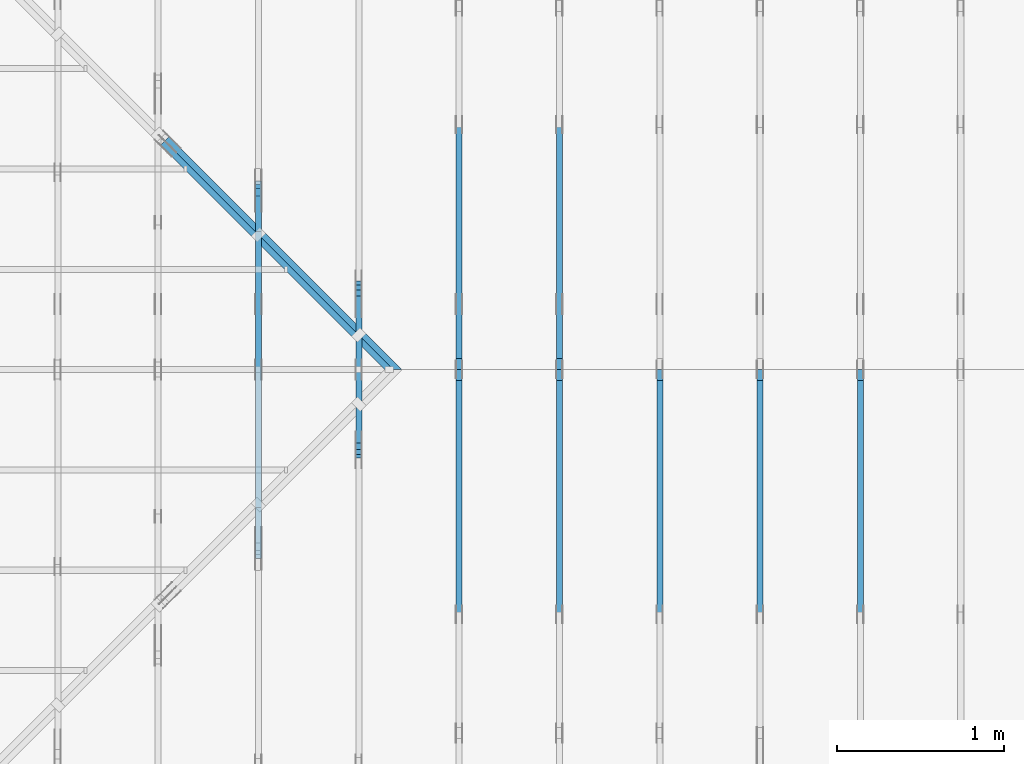
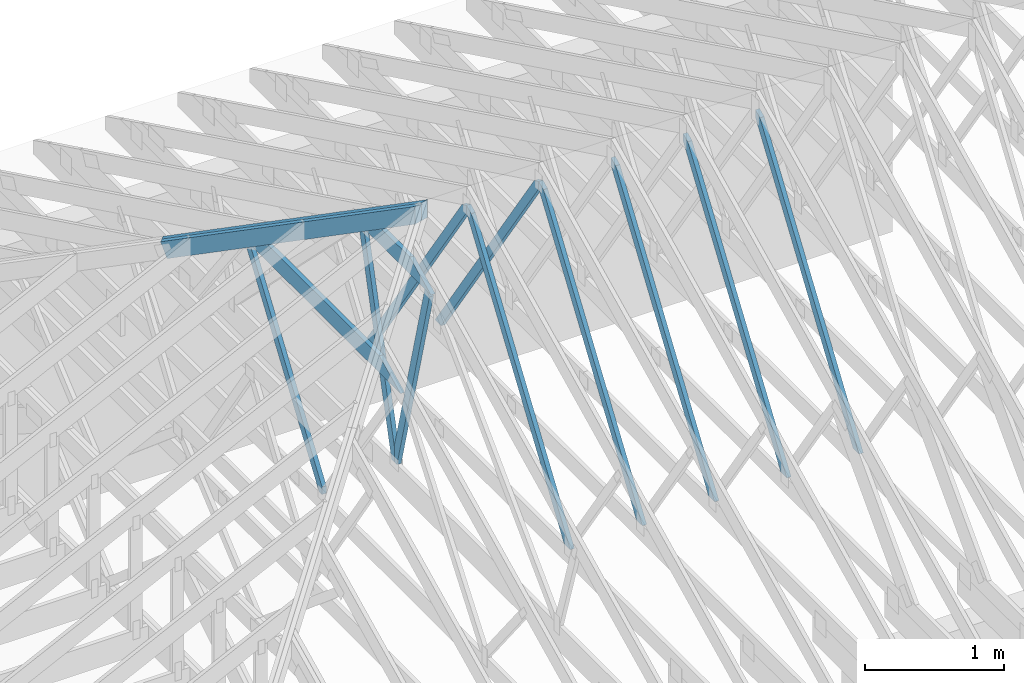
# One storey, part 9 of 159: 14 members, 8 elements without a shape of their own.
"""IFC2X3 building model written with IfcOpenShell, lengths in millimetres."""

from ifc_helpers import new_model, si_unit, frame, origin, origin_with_axes, origin_2d, place, context, project, spatial, faceted_brep, element, aggregate, save


model = new_model("IFC2X3")

# Units and contexts
model_context = context("Model", 3, precision=1e-05, world=origin())
plan_context = context("Plan", 2, precision=1e-05, world=origin_2d())
ifc_project = project(units=[si_unit("LENGTHUNIT", "METRE", prefix="MILLI"), si_unit("AREAUNIT", "SQUARE_METRE"), si_unit("VOLUMEUNIT", "CUBIC_METRE"), si_unit("SOLIDANGLEUNIT", "STERADIAN"), si_unit("PLANEANGLEUNIT", "RADIAN"), si_unit("MASSUNIT", "GRAM"), si_unit("TIMEUNIT", "SECOND"), si_unit("THERMODYNAMICTEMPERATUREUNIT", "DEGREE_CELSIUS"), si_unit("LUMINOUSINTENSITYUNIT", "LUMEN")], contexts=[model_context, plan_context])

# Site, building, storey
site_placement = place(None, origin_with_axes())
site = spatial("IfcSite", under=ifc_project, at=site_placement, CompositionType="ELEMENT")
building_placement = place(site_placement, origin_with_axes())
building = spatial("IfcBuilding", under=site, at=building_placement, Name="Plan 1", CompositionType="ELEMENT")
storey_placement = place(building_placement, origin_with_axes())
storey = spatial("IfcBuildingStorey", under=building, at=storey_placement, Name="Etasje 1", CompositionType="ELEMENT", Elevation=0.0)

# Assembly, member
assembly_1_placement = place(storey_placement, frame((7275.0222614047525, 9699.99999999999, 1.1021457184401395e-15), z_axis=(-1.0, 1.836909530733566e-16, 6.123031769111886e-17), x_axis=(-1.836909530733566e-16, -1.0, 0.0)))
assembly_1 = element("IfcElementAssembly", 1, at=assembly_1_placement, inside=storey, Name="T2 (90)", AssemblyPlace="FACTORY", PredefinedType="TRUSS")
member_1_placement = place(assembly_1_placement, frame((5169.864836410244, 2470.9491092698727, -36.0), z_axis=(0.0, 0.0, 1.0), x_axis=(0.5642475050070653, -0.8256056886270235, 0.0)))
member_1 = element("IfcMember", 2, at=member_1_placement, Name="T2-D10", context=model_context, shape_type="Brep", body=[
    faceted_brep([(2593.4163311647535, 73.00017519343237, 36.0), (64.12142578858538, 73.00017519343237, 36.0), (0.0, 36.50008196845101, 36.0), (53.406771110838235, 4.597682982421247e-05, 36.0), (2543.525610853865, 4.597682982421247e-05, 36.0), (64.12142578858538, 73.00017519343237, 7.85235054368517e-15), (2593.4163311647535, 73.00017519343237, 3.175914117251076e-13), (2543.525610853865, 4.597682982421247e-05, 3.1148176241615866e-13), (53.406771110838235, 4.597682982421247e-05, 6.540227123946988e-15), (0.0, 36.50008196845101, 0.0), (3.725174792457153e-05, 36.50000000048476, 5.564110112461459e-32), (3.725174792634789e-05, 36.50000000048476, 36.0), (64.12144158370505, 73.0000000000009, 36.0), (64.12144158370505, 73.0000000000009, -5.058610251535388e-31), (53.40675570041139, -3.552713678800501e-15, 3.944304526105059e-31), (53.40675570041139, 0.0, 36.0), (3.725174792634789e-05, 36.50000000048476, 36.0), (3.725174792634789e-05, 36.50000000048476, 0.0), (2543.5254846197568, 1.0633235970486703e-11, -9.418992127807544e-29), (2543.5254846197568, 1.0635440261923583e-11, 36.0), (53.406755700411395, 3.450395691825015e-14, 36.0), (53.406755700411395, 3.229966548136987e-14, -1.9777187787411422e-30), (2593.4162114315045, 73.00000000000773, 2.524354896707238e-29), (2593.4162114315045, 73.00000000000773, 36.0), (2543.525484619757, 8.86757334228605e-12, 36.0), (2543.525484619757, 8.86757334228605e-12, 0.0), (64.12144158370506, 73.00000000000092, 0.0), (64.12144158370506, 73.00000000000092, 36.0), (2593.416211431504, 73.00000000000863, 36.0), (2593.416211431504, 73.00000000000863, 2.68212707775144e-29)], [[[0, 1, 2, 3, 4]], [[5, 6, 7, 8, 9]], [[10, 11, 12, 13]], [[14, 15, 16, 17]], [[18, 19, 20, 21]], [[22, 23, 24, 25]], [[26, 27, 28, 29]]]),
])
aggregate(assembly_1, [member_1])

assembly_2_placement = place(storey_placement, frame((6675.0222614047525, 9699.99999999999, 1.1021457184401395e-15), z_axis=(-1.0, 1.836909530733566e-16, 6.123031769111886e-17), x_axis=(-1.836909530733566e-16, -1.0, 0.0)))
assembly_2 = element("IfcElementAssembly", 3, at=assembly_2_placement, inside=storey, Name="T2 (89)", AssemblyPlace="FACTORY", PredefinedType="TRUSS")
member_2_placement = place(assembly_2_placement, frame((5169.864836410244, 2470.9491092698727, -36.0), z_axis=(0.0, 0.0, 1.0), x_axis=(0.5642475050070653, -0.8256056886270235, 0.0)))
member_2 = element("IfcMember", 4, at=member_2_placement, Name="T2-D10", context=model_context, shape_type="Brep", body=[
    faceted_brep([(2593.4163311647535, 73.00017519343237, 36.0), (64.12142578858538, 73.00017519343237, 36.0), (0.0, 36.50008196845101, 36.0), (53.406771110838235, 4.597682982421247e-05, 36.0), (2543.525610853865, 4.597682982421247e-05, 36.0), (64.12142578858538, 73.00017519343237, 7.85235054368517e-15), (2593.4163311647535, 73.00017519343237, 3.175914117251076e-13), (2543.525610853865, 4.597682982421247e-05, 3.1148176241615866e-13), (53.406771110838235, 4.597682982421247e-05, 6.540227123946988e-15), (0.0, 36.50008196845101, 0.0), (3.725174792457153e-05, 36.50000000048476, 5.564110112461459e-32), (3.725174792634789e-05, 36.50000000048476, 36.0), (64.12144158370505, 73.0000000000009, 36.0), (64.12144158370505, 73.0000000000009, -5.058610251535388e-31), (53.40675570041139, -3.552713678800501e-15, 3.944304526105059e-31), (53.40675570041139, 0.0, 36.0), (3.725174792634789e-05, 36.50000000048476, 36.0), (3.725174792634789e-05, 36.50000000048476, 0.0), (2543.5254846197568, 1.0633235970486703e-11, -9.418992127807544e-29), (2543.5254846197568, 1.0635440261923583e-11, 36.0), (53.406755700411395, 3.450395691825015e-14, 36.0), (53.406755700411395, 3.229966548136987e-14, -1.9777187787411422e-30), (2593.4162114315045, 73.00000000000773, 2.524354896707238e-29), (2593.4162114315045, 73.00000000000773, 36.0), (2543.525484619757, 8.86757334228605e-12, 36.0), (2543.525484619757, 8.86757334228605e-12, 0.0), (64.12144158370506, 73.00000000000092, 0.0), (64.12144158370506, 73.00000000000092, 36.0), (2593.416211431504, 73.00000000000863, 36.0), (2593.416211431504, 73.00000000000863, 2.68212707775144e-29)], [[[0, 1, 2, 3, 4]], [[5, 6, 7, 8, 9]], [[10, 11, 12, 13]], [[14, 15, 16, 17]], [[18, 19, 20, 21]], [[22, 23, 24, 25]], [[26, 27, 28, 29]]]),
])
aggregate(assembly_2, [member_2])

# Assembly, members
assembly_3_placement = place(storey_placement, frame((5475.0222614047525, 9699.99999999999, 1.1021457184401395e-15), z_axis=(-1.0, 1.836909530733566e-16, 6.123031769111886e-17), x_axis=(-1.836909530733566e-16, -1.0, 0.0)))
assembly_3 = element("IfcElementAssembly", 5, at=assembly_3_placement, inside=storey, Name="T1 (87)", AssemblyPlace="FACTORY", PredefinedType="TRUSS")
member_3_placement = place(assembly_3_placement, frame((5169.864827117615, 2512.139275987297, -36.0), z_axis=(0.0, 0.0, 1.0), x_axis=(-0.564247505007381, -0.8256056886268078, 0.0)))
member_3 = element("IfcMember", 6, at=member_3_placement, Name="T1-D10", context=model_context, shape_type="Brep", body=[
    faceted_brep([(2543.525473098112, 73.00019205182707, 36.0), (53.406771110823684, 73.00019205182707, 36.0), (0.0, 36.5000932239891, 36.0), (64.12142578859857, 0.00011835385657832376, 36.0), (2593.4163311647667, 0.00011835385657832376, 36.0), (53.406771110823684, 73.00019205182707, 6.540227123945206e-15), (2543.525473098112, 73.00019205182707, 3.114817455465016e-13), (2593.4163311647667, 0.00011835385657832376, 3.175914117251092e-13), (64.12142578859857, 0.00011835385657832376, 7.852350543686785e-15), (0.0, 36.5000932239891, 0.0), (8.990056994662154e-05, 36.50009815631665, 3.944304526105059e-31), (8.990056994662154e-05, 36.50009815631665, 36.0), (53.40680834923387, 73.00009815680099, 36.0), (53.40680834923387, 73.00009815680099, 7.888609052210118e-31), (64.12149423256596, 9.815680185809583e-05, 6.171430365172586e-31), (64.12149423256596, 9.815680186164855e-05, 36.0), (8.990056995195062e-05, 36.50009815631667, 36.0), (8.990056995017426e-05, 36.50009815631666, -3.3878954237129854e-31), (2593.4162640810096, 9.815680364966906e-05, 2.3313020864942917e-30), (2593.4162640810096, 9.815680365187335e-05, 36.0), (64.12149423256596, 9.815680187001689e-05, 36.0), (64.12149423256596, 9.81568018678126e-05, 5.76409767496333e-32), (2543.5255372692222, 73.00009815680278, 0.0), (2543.5255372692222, 73.00009815680278, 36.0), (2593.4162640810096, 9.815680414249073e-05, 36.0), (2593.4162640810096, 9.815680414249073e-05, 0.0), (53.40680834923387, 73.00009815680097, 7.888609052210118e-31), (53.40680834923387, 73.00009815680097, 36.0), (2543.525537269222, 73.00009815680359, 36.0), (2543.525537269222, 73.00009815680359, 4.9698237028923744e-29)], [[[0, 1, 2, 3, 4]], [[5, 6, 7, 8, 9]], [[10, 11, 12, 13]], [[14, 15, 16, 17]], [[18, 19, 20, 21]], [[22, 23, 24, 25]], [[26, 27, 28, 29]]]),
])
member_4_placement = place(assembly_3_placement, frame((5169.864836410244, 2470.9491092698727, -36.0), z_axis=(0.0, 0.0, 1.0), x_axis=(0.5642475050070653, -0.8256056886270235, 0.0)))
member_4 = element("IfcMember", 7, at=member_4_placement, Name="T1-D10", context=model_context, shape_type="Brep", body=[
    faceted_brep([(2593.4163311647535, 73.00017519343237, 36.0), (64.12142578858538, 73.00017519343237, 36.0), (0.0, 36.50008196845101, 36.0), (53.406771110838235, 4.597682982421247e-05, 36.0), (2543.525610853865, 4.597682982421247e-05, 36.0), (64.12142578858538, 73.00017519343237, 7.85235054368517e-15), (2593.4163311647535, 73.00017519343237, 3.175914117251076e-13), (2543.525610853865, 4.597682982421247e-05, 3.1148176241615866e-13), (53.406771110838235, 4.597682982421247e-05, 6.540227123946988e-15), (0.0, 36.50008196845101, 0.0), (3.725174792457153e-05, 36.50000000048476, 5.564110112461459e-32), (3.725174792634789e-05, 36.50000000048476, 36.0), (64.12144158370505, 73.0000000000009, 36.0), (64.12144158370505, 73.0000000000009, -5.058610251535388e-31), (53.40675570041139, -3.552713678800501e-15, 3.944304526105059e-31), (53.40675570041139, 0.0, 36.0), (3.725174792634789e-05, 36.50000000048476, 36.0), (3.725174792634789e-05, 36.50000000048476, 0.0), (2543.5254846197568, 1.0633235970486703e-11, -9.418992127807544e-29), (2543.5254846197568, 1.0635440261923583e-11, 36.0), (53.406755700411395, 3.450395691825015e-14, 36.0), (53.406755700411395, 3.229966548136987e-14, -1.9777187787411422e-30), (2593.4162114315045, 73.00000000000773, 2.524354896707238e-29), (2593.4162114315045, 73.00000000000773, 36.0), (2543.525484619757, 8.86757334228605e-12, 36.0), (2543.525484619757, 8.86757334228605e-12, 0.0), (64.12144158370506, 73.00000000000092, 0.0), (64.12144158370506, 73.00000000000092, 36.0), (2593.416211431504, 73.00000000000863, 36.0), (2593.416211431504, 73.00000000000863, 2.68212707775144e-29)], [[[0, 1, 2, 3, 4]], [[5, 6, 7, 8, 9]], [[10, 11, 12, 13]], [[14, 15, 16, 17]], [[18, 19, 20, 21]], [[22, 23, 24, 25]], [[26, 27, 28, 29]]]),
])
aggregate(assembly_3, [member_3, member_4])

assembly_4_placement = place(storey_placement, frame((4875.0222614047525, 9699.99999999999, 1.1021457184401395e-15), z_axis=(-1.0, 1.836909530733566e-16, 6.123031769111886e-17), x_axis=(-1.836909530733566e-16, -1.0, 0.0)))
assembly_4 = element("IfcElementAssembly", 8, at=assembly_4_placement, inside=storey, Name="T1 (86)", AssemblyPlace="FACTORY", PredefinedType="TRUSS")
member_5_placement = place(assembly_4_placement, frame((5169.864827117615, 2512.139275987297, -36.0), z_axis=(0.0, 0.0, 1.0), x_axis=(-0.564247505007381, -0.8256056886268078, 0.0)))
member_5 = element("IfcMember", 9, at=member_5_placement, Name="T1-D10", context=model_context, shape_type="Brep", body=[
    faceted_brep([(2543.525473098112, 73.00019205182707, 36.0), (53.406771110823684, 73.00019205182707, 36.0), (0.0, 36.5000932239891, 36.0), (64.12142578859857, 0.00011835385657832376, 36.0), (2593.4163311647667, 0.00011835385657832376, 36.0), (53.406771110823684, 73.00019205182707, 6.540227123945206e-15), (2543.525473098112, 73.00019205182707, 3.114817455465016e-13), (2593.4163311647667, 0.00011835385657832376, 3.175914117251092e-13), (64.12142578859857, 0.00011835385657832376, 7.852350543686785e-15), (0.0, 36.5000932239891, 0.0), (8.990056994662154e-05, 36.50009815631665, 3.944304526105059e-31), (8.990056994662154e-05, 36.50009815631665, 36.0), (53.40680834923387, 73.00009815680099, 36.0), (53.40680834923387, 73.00009815680099, 7.888609052210118e-31), (64.12149423256596, 9.815680185809583e-05, 6.171430365172586e-31), (64.12149423256596, 9.815680186164855e-05, 36.0), (8.990056995195062e-05, 36.50009815631667, 36.0), (8.990056995017426e-05, 36.50009815631666, -3.3878954237129854e-31), (2593.4162640810096, 9.815680364966906e-05, 2.3313020864942917e-30), (2593.4162640810096, 9.815680365187335e-05, 36.0), (64.12149423256596, 9.815680187001689e-05, 36.0), (64.12149423256596, 9.81568018678126e-05, 5.76409767496333e-32), (2543.5255372692222, 73.00009815680278, 0.0), (2543.5255372692222, 73.00009815680278, 36.0), (2593.4162640810096, 9.815680414249073e-05, 36.0), (2593.4162640810096, 9.815680414249073e-05, 0.0), (53.40680834923387, 73.00009815680097, 7.888609052210118e-31), (53.40680834923387, 73.00009815680097, 36.0), (2543.525537269222, 73.00009815680359, 36.0), (2543.525537269222, 73.00009815680359, 4.9698237028923744e-29)], [[[0, 1, 2, 3, 4]], [[5, 6, 7, 8, 9]], [[10, 11, 12, 13]], [[14, 15, 16, 17]], [[18, 19, 20, 21]], [[22, 23, 24, 25]], [[26, 27, 28, 29]]]),
])
member_6_placement = place(assembly_4_placement, frame((5169.864836410244, 2470.9491092698727, -36.0), z_axis=(0.0, 0.0, 1.0), x_axis=(0.5642475050070653, -0.8256056886270235, 0.0)))
member_6 = element("IfcMember", 10, at=member_6_placement, Name="T1-D10", context=model_context, shape_type="Brep", body=[
    faceted_brep([(2593.4163311647535, 73.00017519343237, 36.0), (64.12142578858538, 73.00017519343237, 36.0), (0.0, 36.50008196845101, 36.0), (53.406771110838235, 4.597682982421247e-05, 36.0), (2543.525610853865, 4.597682982421247e-05, 36.0), (64.12142578858538, 73.00017519343237, 7.85235054368517e-15), (2593.4163311647535, 73.00017519343237, 3.175914117251076e-13), (2543.525610853865, 4.597682982421247e-05, 3.1148176241615866e-13), (53.406771110838235, 4.597682982421247e-05, 6.540227123946988e-15), (0.0, 36.50008196845101, 0.0), (3.725174792457153e-05, 36.50000000048476, 5.564110112461459e-32), (3.725174792634789e-05, 36.50000000048476, 36.0), (64.12144158370505, 73.0000000000009, 36.0), (64.12144158370505, 73.0000000000009, -5.058610251535388e-31), (53.40675570041139, -3.552713678800501e-15, 3.944304526105059e-31), (53.40675570041139, 0.0, 36.0), (3.725174792634789e-05, 36.50000000048476, 36.0), (3.725174792634789e-05, 36.50000000048476, 0.0), (2543.5254846197568, 1.0633235970486703e-11, -9.418992127807544e-29), (2543.5254846197568, 1.0635440261923583e-11, 36.0), (53.406755700411395, 3.450395691825015e-14, 36.0), (53.406755700411395, 3.229966548136987e-14, -1.9777187787411422e-30), (2593.4162114315045, 73.00000000000773, 2.524354896707238e-29), (2593.4162114315045, 73.00000000000773, 36.0), (2543.525484619757, 8.86757334228605e-12, 36.0), (2543.525484619757, 8.86757334228605e-12, 0.0), (64.12144158370506, 73.00000000000092, 0.0), (64.12144158370506, 73.00000000000092, 36.0), (2593.416211431504, 73.00000000000863, 36.0), (2593.416211431504, 73.00000000000863, 2.68212707775144e-29)], [[[0, 1, 2, 3, 4]], [[5, 6, 7, 8, 9]], [[10, 11, 12, 13]], [[14, 15, 16, 17]], [[18, 19, 20, 21]], [[22, 23, 24, 25]], [[26, 27, 28, 29]]]),
])
aggregate(assembly_4, [member_5, member_6])

assembly_5_placement = place(storey_placement, frame((-725.455844122723, 9674.544155877278, 2.204291436880279e-15), z_axis=(-0.7071067811865477, -0.7071067811865474, 6.123031769111886e-17), x_axis=(0.7071067811865474, -0.7071067811865477, 0.0)))
assembly_5 = element("IfcElementAssembly", 11, at=assembly_5_placement, inside=storey, Name="GR1 (7)", AssemblyPlace="FACTORY", PredefinedType="TRUSS")
member_7_placement = place(assembly_5_placement, frame((5468.934471170818, 1837.150671481754, -36.00000195234122), z_axis=(0.0, 0.0, 1.0), x_axis=(0.9453579955214152, 0.32603413978252627, 0.0)))
member_7 = element("IfcMember", 12, at=member_7_placement, Name="GR1-O54.1", context=model_context, shape_type="Brep", body=[
    faceted_brep([(2044.9695853527853, 148.00000217906904, 3.895812142218347e-06), (2006.888773817072, 147.99999829813834, 36.000002291727014), (1955.8466796875005, 5.297806637827307e-11, 36.00000195234145), (1993.9274912232138, 2.541803496569628e-07, 2.3739650032439386e-06), (0.00010288836256222567, 148.00000000101932, 1.952341222022369e-06), (0.00010288836256222567, 148.00000000101932, 36.00000195234122), (2006.8887747633617, 148.00000000101966, 36.00000195234122), (2044.9695853102367, 148.00000000101966, 1.952341222022369e-06), (0.00010423553885630099, 148.0000000027635, 1.9523412220223817e-06), (2044.9695866574139, 148.0000000027635, 1.952341472450644e-06), (1993.9274914730877, 9.86574377748184e-10, 1.9523414661999965e-06), (0.00010423553885630099, 9.86574377748184e-10, 1.9523412220223817e-06), (5.277855416352395e-05, 3.7843392419745214e-07, 1.8783537143463036e-06), (5.277855325445718e-05, 3.7843392419745214e-07, 36.00000195234122), (5.277855327258134e-05, 148.00000315368334, 36.00000255341424), (5.277855418164817e-05, 148.00000315368334, 4.576700956714107e-28), (1993.927491581545, -3.662664415573603e-13, 1.952341222022369e-06), (1955.84668103467, -3.5706704973731863e-13, 36.00000195234122), (1.3471708371071145e-06, 2.204290919838e-15, 36.00000195234122), (1.3471708371071145e-06, -5.170422792220365e-22, 1.952341222022369e-06), (2006.8887748718253, 148.00000000005298, 36.00000195234122), (0.0, 148.00000000005298, 36.00000195234122), (0.0, 2.7632722776615992e-09, 36.00000195234122), (1955.8466796875, 2.7632722776615992e-09, 36.00000195234122)], [[[0, 1, 2, 3]], [[4, 5, 6, 7]], [[8, 9, 10, 11]], [[12, 13, 14, 15]], [[16, 17, 18, 19]], [[20, 21, 22, 23]]]),
])
member_8_placement = place(assembly_5_placement, frame((5468.934472444393, 1837.1506719209274, -72.00000195234122), z_axis=(0.0, 0.0, 1.0), x_axis=(0.9453579955214152, 0.32603413978252627, 0.0)))
member_8 = element("IfcMember", 13, at=member_8_placement, Name="GR1-O54.1", context=model_context, shape_type="Brep", body=[
    faceted_brep([(2083.0503958999657, 148.0000021788719, 3.895756890415214e-06), (2044.9695843641184, 147.99999829807945, 36.000002291530336), (1993.927490234375, 5.32054400537163e-11, 36.00000195234122), (2032.0083017702218, 2.5404278858331963e-07, 2.3741063159832265e-06), (0.00010288836801919388, 148.00000000104, 1.952341222022369e-06), (0.00010288836801919388, 148.00000000104, 36.00000195234122), (2044.969585310244, 148.0000000010394, 36.00000195234122), (2083.050395857119, 148.0000000010394, 1.952341222022369e-06), (5.143138423591154e-05, 3.784869022638304e-07, 1.8783537143463036e-06), (5.143138332684477e-05, 3.784869022638304e-07, 36.00000195234122), (5.143138334496893e-05, 148.00000315373632, 36.00000255341424), (5.143138425403576e-05, 148.00000315373632, 4.576700956714107e-28), (2032.0083021287628, -3.7326154150329567e-13, 1.952341222022369e-06), (1993.9274915818878, 9.157337962291024e-14, 36.00000195234122), (1.3475118976202793e-06, 4.578398206632287e-13, 36.00000195234122), (1.3475118976202793e-06, -7.981584533867967e-23, 1.952341222022369e-06), (2044.9695854187012, 148.00000000005366, 36.00000195234122), (0.0, 148.00000000005366, 36.00000195234122), (0.0, 2.8164777177153155e-09, 36.00000195234122), (1993.927490234375, 2.8164777177153155e-09, 36.00000195234122), (0.00010423588628327707, 148.00000000281625, 1.9523412220223817e-06), (2083.050397204637, 148.00000000281625, 1.952341477114044e-06), (2032.00830202031, 1.0068106348626316e-09, 1.952341470863397e-06), (0.00010423588719277177, 1.0068106348626316e-09, 1.9523412220223817e-06)], [[[0, 1, 2, 3]], [[4, 5, 6, 7]], [[8, 9, 10, 11]], [[12, 13, 14, 15]], [[16, 17, 18, 19]], [[20, 21, 22, 23]]]),
])
aggregate(assembly_5, [member_7, member_8])

assembly_6_placement = place(storey_placement, frame((3675.02226140475, 9699.999999999993, 1.1021457184401395e-15), z_axis=(-1.0, 1.836909530733566e-16, 6.123031769111886e-17), x_axis=(-1.836909530733566e-16, -1.0, 0.0)))
assembly_6 = element("IfcElementAssembly", 14, at=assembly_6_placement, inside=storey, Name="V4 (5)", AssemblyPlace="FACTORY", PredefinedType="TRUSS")
member_9_placement = place(assembly_6_placement, frame((4071.5772928510996, 1941.1758453978764, -36.0), z_axis=(0.0, 0.0, 1.0), x_axis=(1.0, 0.0, 0.0)))
member_9 = element("IfcMember", 15, at=member_9_placement, Name="V4-O52", context=model_context, shape_type="Brep", body=[
    faceted_brep([(1953.3992696489004, 147.9999358521236, 36.0), (303.4451680864004, 147.9999358521236, 36.0), (9.97270253719762e-05, 5.79224360990338e-05, 36.0), (2256.8445821489004, 5.79224360990338e-05, 36.0), (303.4451680864004, 147.9999358521236, 3.7160088087530516e-14), (1953.3992696489004, 147.9999358521236, 2.3921451571640344e-13), (2256.8445821489004, 5.79224360990338e-05, 2.763746214889151e-13), (9.97270253719762e-05, 5.79224360990338e-05, 1.2212634891832748e-20), (-1.0184798680605127e-14, 1.4572797160227418e-11, 1.4225809873699785e-30), (-9.218500915562698e-15, 1.457081595620764e-11, 36.0), (303.4449685538421, 148.00000000000722, 36.0), (303.4449685538421, 148.00000000000722, -3.951237873904853e-30), (2256.844344427198, 1.0599023640320796e-13, -6.489815847125323e-30), (2256.844344427198, 1.0819452784008824e-13, 36.0), (1.410953698965989e-29, 1.4554119519803732e-11, 36.0), (0.0, 1.4551915228366852e-11, 0.0), (1953.3993758734434, 148.0000000000001, 7.41151830467227e-30), (1953.3993758734434, 148.0000000000001, 36.0), (2256.844344427198, 2.2737367544323206e-13, 36.0), (2256.844344427198, 2.2737367544323206e-13, 6.371166506495292e-30), (303.444968553842, 148.00000000000725, -1.5777218104420236e-30), (303.444968553842, 148.00000000000725, 36.0), (1953.3993758734432, 147.9999999999998, 36.0), (1953.3993758734432, 147.99999999999983, -1.1044052673094165e-29)], [[[0, 1, 2, 3]], [[4, 5, 6, 7]], [[8, 9, 10, 11]], [[12, 13, 14, 15]], [[16, 17, 18, 19]], [[20, 21, 22, 23]]]),
])
member_10_placement = place(assembly_6_placement, frame((4087.425808578242, 1920.4581407281698, -36.0), z_axis=(0.0, 0.0, 1.0), x_axis=(0.5676061629790939, -0.8233002148354817, 0.0)))
member_10 = element("IfcMember", 16, at=member_10_placement, Name="V4-D17", context=model_context, shape_type="Brep", body=[
    faceted_brep([(1854.2304709005057, 73.00017562337689, 36.0), (25.164020344358732, 73.00017562337689, 36.0), (5.47351367004012e-05, 36.5003218901893, 36.0), (11.924960228313012, 0.00011002184874087106, 36.0), (1882.008668050445, 0.00011002184874087106, 36.0), (1907.1729108111135, 36.5003218901893, 36.0), (25.164020344358732, 73.00017562337689, 3.081601920141727e-15), (1854.2304709005057, 73.00017562337689, 2.2707024161158178e-13), (1907.1729108111135, 36.5003218901893, 2.335536064417208e-13), (1882.008668050445, 0.00011002184874087106, 2.304719772843364e-13), (11.924960228313012, 0.00011002184874087106, 1.460338206467126e-15), (5.47351367004012e-05, 36.5003218901893, 6.70289961806477e-21), (-1.0658141036401503e-14, 36.50014045123044, 7.768466366807374e-31), (-7.105427357601002e-15, 36.50014045123044, 36.0), (25.16411944927357, 73.00014045122226, 36.0), (25.16411944927357, 73.00014045122226, 1.4445050241938607e-30), (11.924987637655475, 0.00014045122225025963, 9.860761315262648e-32), (11.924987637655477, 0.0001404512222511478, 36.0), (7.105427357601002e-15, 36.50014045123045, 36.0), (5.329070518200751e-15, 36.50014045123045, -4.930380657631324e-31), (1882.0087648814429, 0.00014045122522491653, 4.0642603203748335e-29), (1882.0087648814429, 0.00014045122522712082, 36.0), (11.924987637655477, 0.00014045122224870218, 36.0), (11.924987637655477, 0.00014045122224649789, 2.575239169544164e-31), (1907.1728843307187, 36.500140451221455, -1.262177448353619e-29), (1907.1728843307187, 36.500140451221455, 36.0), (1882.0087648814429, 0.0001404512261160562, 36.0), (1882.0087648814429, 0.0001404512261160562, 0.0), (1854.2304397247494, 73.00014045121839, -3.7865323450608567e-29), (1854.2304397247494, 73.00014045121839, 36.0), (1907.1728843307183, 36.500140451221114, 36.0), (1907.1728843307183, 36.500140451221114, -2.524354896707238e-29), (25.164119449273585, 73.00014045122225, 0.0), (25.164119449273585, 73.00014045122225, 36.0), (1854.2304397247499, 73.00014045121848, 36.0), (1854.2304397247499, 73.00014045121848, -7.099748146989106e-30)], [[[0, 1, 2, 3, 4, 5]], [[6, 7, 8, 9, 10, 11]], [[12, 13, 14, 15]], [[16, 17, 18, 19]], [[20, 21, 22, 23]], [[24, 25, 26, 27]], [[28, 29, 30, 31]], [[32, 33, 34, 35]]]),
])
aggregate(assembly_6, [member_9, member_10])

# Assembly, member
assembly_7_placement = place(storey_placement, frame((6075.0222614047525, 9699.99999999999, 1.1021457184401395e-15), z_axis=(-1.0, 1.836909530733566e-16, 6.123031769111886e-17), x_axis=(-1.836909530733566e-16, -1.0, 0.0)))
assembly_7 = element("IfcElementAssembly", 17, at=assembly_7_placement, inside=storey, Name="T1 (88)", AssemblyPlace="FACTORY", PredefinedType="TRUSS")
member_11_placement = place(assembly_7_placement, frame((5169.864836410244, 2470.9491092698727, -36.0), z_axis=(0.0, 0.0, 1.0), x_axis=(0.5642475050070653, -0.8256056886270235, 0.0)))
member_11 = element("IfcMember", 18, at=member_11_placement, Name="T1-D10", context=model_context, shape_type="Brep", body=[
    faceted_brep([(2593.4163311647535, 73.00017519343237, 36.0), (64.12142578858538, 73.00017519343237, 36.0), (0.0, 36.50008196845101, 36.0), (53.406771110838235, 4.597682982421247e-05, 36.0), (2543.525610853865, 4.597682982421247e-05, 36.0), (64.12142578858538, 73.00017519343237, 7.85235054368517e-15), (2593.4163311647535, 73.00017519343237, 3.175914117251076e-13), (2543.525610853865, 4.597682982421247e-05, 3.1148176241615866e-13), (53.406771110838235, 4.597682982421247e-05, 6.540227123946988e-15), (0.0, 36.50008196845101, 0.0), (3.725174792457153e-05, 36.50000000048476, 5.564110112461459e-32), (3.725174792634789e-05, 36.50000000048476, 36.0), (64.12144158370505, 73.0000000000009, 36.0), (64.12144158370505, 73.0000000000009, -5.058610251535388e-31), (53.40675570041139, -3.552713678800501e-15, 3.944304526105059e-31), (53.40675570041139, 0.0, 36.0), (3.725174792634789e-05, 36.50000000048476, 36.0), (3.725174792634789e-05, 36.50000000048476, 0.0), (2543.5254846197568, 1.0633235970486703e-11, -9.418992127807544e-29), (2543.5254846197568, 1.0635440261923583e-11, 36.0), (53.406755700411395, 3.450395691825015e-14, 36.0), (53.406755700411395, 3.229966548136987e-14, -1.9777187787411422e-30), (2593.4162114315045, 73.00000000000773, 2.524354896707238e-29), (2593.4162114315045, 73.00000000000773, 36.0), (2543.525484619757, 8.86757334228605e-12, 36.0), (2543.525484619757, 8.86757334228605e-12, 0.0), (64.12144158370506, 73.00000000000092, 0.0), (64.12144158370506, 73.00000000000092, 36.0), (2593.416211431504, 73.00000000000863, 36.0), (2593.416211431504, 73.00000000000863, 2.68212707775144e-29)], [[[0, 1, 2, 3, 4]], [[5, 6, 7, 8, 9]], [[10, 11, 12, 13]], [[14, 15, 16, 17]], [[18, 19, 20, 21]], [[22, 23, 24, 25]], [[26, 27, 28, 29]]]),
])
aggregate(assembly_7, [member_11])

# Assembly, members
assembly_8_placement = place(storey_placement, frame((4275.022261406632, 9700.000260373617, 1.1021457184401395e-15), z_axis=(-0.999999999895379, 1.4465201327097478e-05, 6.123031769111886e-17), x_axis=(-1.4465201327097478e-05, -0.999999999895379, 0.0)))
assembly_8 = element("IfcElementAssembly", 19, at=assembly_8_placement, inside=storey, Name="V13 (6)", AssemblyPlace="FACTORY", PredefinedType="TRUSS")
member_12_placement = place(assembly_8_placement, frame((4671.501813920229, 2233.778564453125, -36.0), z_axis=(0.0, 0.0, 1.0), x_axis=(1.0, 0.0, 0.0)))
member_12 = element("IfcMember", 20, at=member_12_placement, Name="V13-O70", context=model_context, shape_type="Brep", body=[
    faceted_brep([(753.5504321735207, 148.0, 36.0), (303.4449634235207, 148.0, 36.0), (0.00013920477067586035, 0.0, 36.0), (1056.9952563922707, 0.0, 36.0), (303.4449634235207, 148.0, 3.716006302438423e-14), (753.5504321735207, 148.0, 9.228026471652918e-14), (1056.9952563922707, 0.0, 1.2944031069380873e-13), (0.00013920477067586035, 0.0, 1.7047104665204552e-20), (-5.751519730314361e-15, 2.0314102596754164e-05, 8.033542803689103e-31), (-4.785221155954866e-15, 2.031410259477296e-05, 36.0), (303.44496858573984, 148.00002031410267, 36.0), (303.44496858573984, 148.00002031410267, 4.471238958889407e-30), (1056.9953033793136, 2.031410239080133e-05, 1.1888507502182514e-29), (1056.9953033793136, 2.031410239300562e-05, 36.0), (4.049083948919771e-31, 2.0314102587166093e-05, 36.0), (0.0, 2.0314102584961802e-05, 0.0), (753.5503347938212, 148.0000203140953, 0.0), (753.5503347938212, 148.0000203140953, 36.0), (1056.9953033793136, 2.0314102584961802e-05, 36.0), (1056.9953033793136, 2.0314102584961802e-05, 0.0), (303.44496858573984, 148.00002031410264, 3.1554436208840472e-30), (303.44496858573984, 148.00002031410264, 36.0), (753.5503347938211, 148.0000203140954, 36.0), (753.5503347938211, 148.00002031409542, 7.888609052210118e-30)], [[[0, 1, 2, 3]], [[4, 5, 6, 7]], [[8, 9, 10, 11]], [[12, 13, 14, 15]], [[16, 17, 18, 19]], [[20, 21, 22, 23]]]),
])
member_13_placement = place(assembly_8_placement, frame((4687.987688582513, 2224.37379512608, -35.99999999999999), z_axis=(0.0, 0.0, 1.0), x_axis=(0.2576642089218034, -0.9662345240368413, 0.0)))
member_13 = element("IfcMember", 21, at=member_13_placement, Name="V13-D19", context=model_context, shape_type="Brep", body=[
    faceted_brep([(1713.3791759762519, 73.00022036113387, 36.0), (9.73337284247259, 73.00022036113387, 36.0), (6.700369794998551e-06, 36.500124873871755, 36.0), (21.004910941586786, 0.0, 36.0), (1840.5199127181452, 0.0, 36.0), (1850.253278860248, 36.500124873871755, 36.0), (9.73337284247259, 73.00022036113387, 1.1919550227014106e-15), (1713.3791759762519, 73.00022036113387, 2.098215025407467e-13), (1850.253278860248, 36.500124873871755, 2.2658319214729465e-13), (1840.5199127181452, 0.0, 2.2539123794512477e-13), (21.004910941586786, 0.0, 2.5722747400540352e-15), (6.700369794998551e-06, 36.500124873871755, 8.205315423914765e-22), (-2.4868995751603507e-14, 36.50017858709089, 1.5676523316787324e-30), (-2.3092638912203256e-14, 36.50017858709089, 36.0), (9.733396387404541, 73.00017858709091, 36.0), (9.733396387404538, 73.00017858709091, 2.9303617577100017e-30), (21.004908959399017, 0.00017858708997486872, 0.0), (21.00490895939902, 0.00017858708997664507, 36.0), (3.552713678800501e-15, 36.500178587090886, 36.0), (1.7763568394002505e-15, 36.500178587090886, -1.9721522630525295e-31), (1840.519870591765, 0.0001785870928554812, 1.0217119743991264e-28), (1840.519870591765, 0.00017858709285768548, 36.0), (21.004908959399017, 0.00017858708995980606, 36.0), (21.004908959399017, 0.00017858708995760177, 1.16602569680664e-30), (1850.253266979169, 36.50017858709168, 1.2621774483536186e-29), (1850.253266979169, 36.50017858709168, 36.0), (1840.5198705917655, 0.00017858709452411858, 36.0), (1840.5198705917655, 0.00017858709452411858, -2.802596928649634e-45), (1713.379153671503, 73.00017858709589, 3.155443620884047e-29), (1713.379153671503, 73.00017858709589, 36.0), (1850.2532669791692, 36.50017858709231, 36.0), (1850.2532669791692, 36.50017858709231, 3.155443620884047e-29), (9.733396387404582, 73.00017858709089, -7.888609052210118e-31), (9.733396387404582, 73.00017858709089, 36.0), (1713.3791536715025, 73.00017858709532, 36.0), (1713.3791536715025, 73.00017858709532, -7.888609052210118e-30)], [[[0, 1, 2, 3, 4, 5]], [[6, 7, 8, 9, 10, 11]], [[12, 13, 14, 15]], [[16, 17, 18, 19]], [[20, 21, 22, 23]], [[24, 25, 26, 27]], [[28, 29, 30, 31]], [[32, 33, 34, 35]]]),
])
member_14_placement = place(assembly_8_placement, frame((5641.47574594207, 2243.183400419221, -36.00000000000001), z_axis=(0.0, 0.0, 1.0), x_axis=(-0.25766420892254444, -0.9662345240366439, 0.0)))
member_14 = element("IfcMember", 22, at=member_14_placement, Name="V13-D19", context=model_context, shape_type="Brep", body=[
    faceted_brep([(1840.5199060177476, 73.00014669033226, 36.0), (21.005030053790506, 73.00014669033226, 36.0), (0.0, 36.500358375046744, 36.0), (9.733491954732472, 0.0, 36.0), (1713.37916927591, 0.0, 36.0), (1850.2532721598782, 36.500358375046744, 36.0), (21.005030053790506, 73.00014669033226, 2.5722893266101846e-15), (1840.5199060177476, 73.00014669033226, 2.2539123712458985e-13), (1850.2532721598782, 36.500358375046744, 2.2658319132676312e-13), (1713.37916927591, 0.0, 2.0982150172021858e-13), (9.733491954732472, 0.0, 1.1919696092644375e-15), (0.0, 36.500358375046744, 0.0), (1.7061410291674406e-05, 36.50021555573039, 0.0), (1.7061410293450763e-05, 36.50021555573039, 36.0), (21.00492602079158, 73.0002155557304, 36.0), (21.00492602079158, 73.0002155557304, -3.944304526105059e-31), (9.733413448844656, 0.000215555730391781, 9.860761315262645e-32), (9.733413448844658, 0.0002155557303922251, 36.0), (1.7061410279239908e-05, 36.50021555573039, 36.0), (1.706141027746355e-05, 36.50021555573039, 4.930380657631324e-31), (1713.379170733318, 0.00021555573310028084, 5.693948385078009e-29), (1713.379170733318, 0.00021555573310248514, 36.0), (9.733413448844658, 0.00021555573038914666, 36.0), (9.733413448844658, 0.00021555573038694237, 3.2346294342537437e-31), (1850.2532840409576, 36.5002155557292, 2.4470660647581692e-29), (1850.2532840409576, 36.5002155557292, 36.0), (1713.3791707333182, 0.00021555573380283022, 36.0), (1713.3791707333182, 0.00021555573380283022, 2.0878701962293907e-29), (1840.5198876535221, 73.00021555573409, 2.524354896707238e-29), (1840.5198876535221, 73.00021555573409, 36.0), (1850.2532840409579, 36.500215555729596, 36.0), (1850.2532840409579, 36.500215555729596, 1.262177448353619e-29), (21.004926020791572, 73.00021555573039, -7.888609052210118e-31), (21.004926020791572, 73.00021555573039, 36.0), (1840.5198876535217, 73.00021555573392, 36.0), (1840.5198876535217, 73.00021555573392, -7.099748146989106e-30)], [[[0, 1, 2, 3, 4, 5]], [[6, 7, 8, 9, 10, 11]], [[12, 13, 14, 15]], [[16, 17, 18, 19]], [[20, 21, 22, 23]], [[24, 25, 26, 27]], [[28, 29, 30, 31]], [[32, 33, 34, 35]]]),
])
aggregate(assembly_8, [member_12, member_13, member_14])

save(model, "model.ifc")
